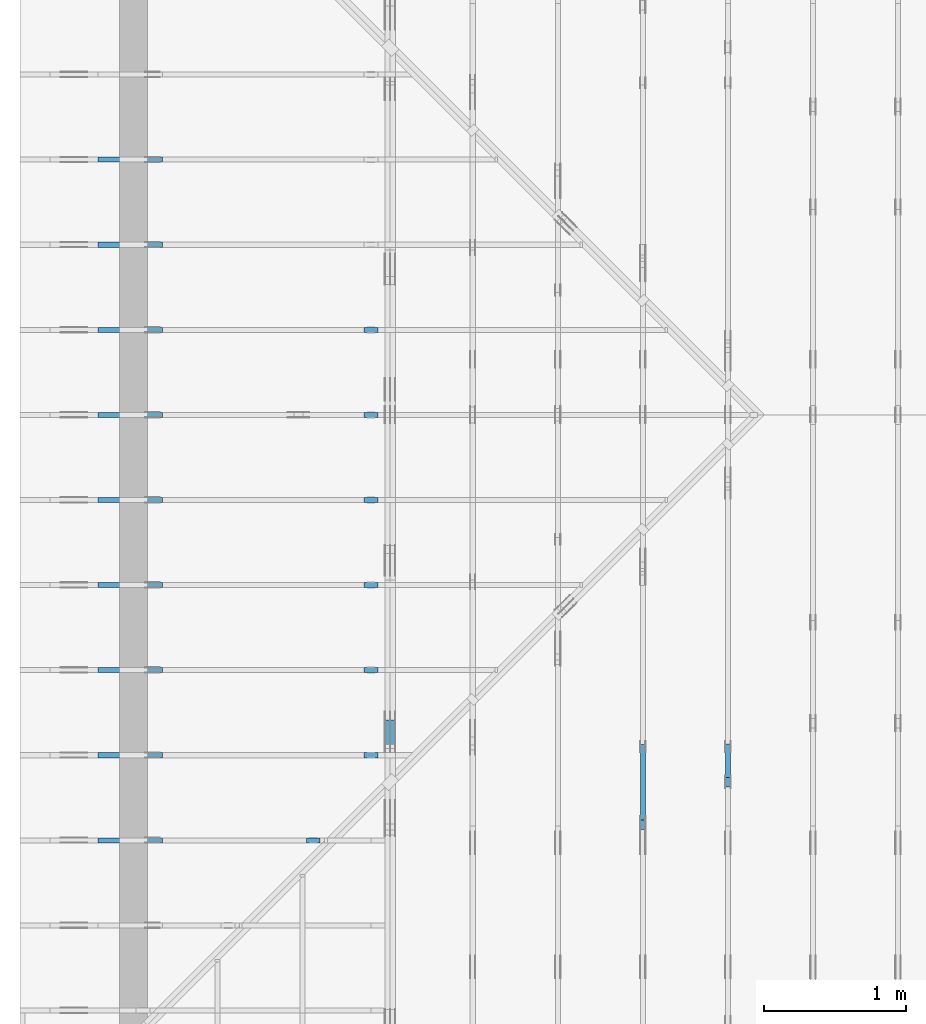
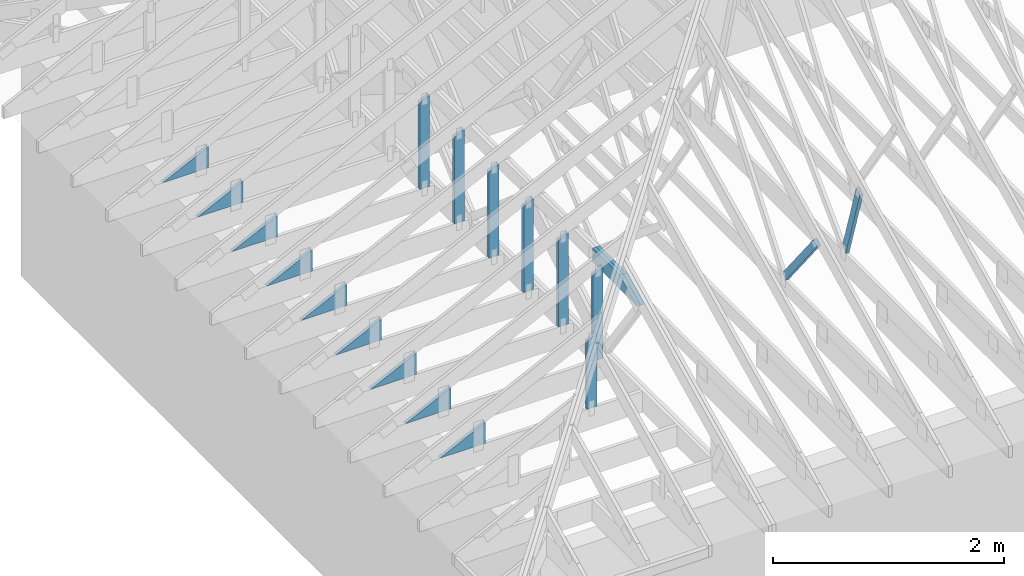
# One storey, part 42 of 159: 20 members, 12 elements without a shape of their own.
"""IFC2X3 building model written with IfcOpenShell, lengths in millimetres."""

from ifc_helpers import new_model, si_unit, frame, origin, origin_with_axes, origin_2d, place, context, project, spatial, faceted_brep, element, aggregate, save


model = new_model("IFC2X3")

# Units and contexts
model_context = context("Model", 3, precision=1e-05, world=origin())
plan_context = context("Plan", 2, precision=1e-05, world=origin_2d())
ifc_project = project(units=[si_unit("LENGTHUNIT", "METRE", prefix="MILLI"), si_unit("AREAUNIT", "SQUARE_METRE"), si_unit("VOLUMEUNIT", "CUBIC_METRE"), si_unit("SOLIDANGLEUNIT", "STERADIAN"), si_unit("PLANEANGLEUNIT", "RADIAN"), si_unit("MASSUNIT", "GRAM"), si_unit("TIMEUNIT", "SECOND"), si_unit("THERMODYNAMICTEMPERATUREUNIT", "DEGREE_CELSIUS"), si_unit("LUMINOUSINTENSITYUNIT", "LUMEN")], contexts=[model_context, plan_context])

# Site, building, storey
site_placement = place(None, origin_with_axes())
site = spatial("IfcSite", under=ifc_project, at=site_placement, CompositionType="ELEMENT")
building_placement = place(site_placement, origin_with_axes())
building = spatial("IfcBuilding", under=site, at=building_placement, Name="Plan 1", CompositionType="ELEMENT")
storey_placement = place(building_placement, origin_with_axes())
storey = spatial("IfcBuildingStorey", under=building, at=storey_placement, Name="Etasje 1", CompositionType="ELEMENT", Elevation=0.0)

# Assembly, members
assembly_1_placement = place(storey_placement, frame((-700.000000000007, 4482.000534935255, 1.1021457184401395e-15), z_axis=(0.0, -1.0, 6.123031769111886e-17), x_axis=(1.0, 0.0, 0.0)))
assembly_1 = element("IfcElementAssembly", 1, at=assembly_1_placement, inside=storey, Name="S1 (23)", AssemblyPlace="FACTORY", PredefinedType="TRUSS")
member_1_placement = place(assembly_1_placement, frame((2427.022216796875, 1186.87060546875, -36.0), z_axis=(0.0, 0.0, 1.0), x_axis=(-1.836909530733566e-16, -1.0, 0.0)))
member_1 = element("IfcMember", 2, at=member_1_placement, Name="S1-S10", context=model_context, shape_type="Brep", body=[
    faceted_brep([(963.87060546875, 98.0, 36.0), (0.0, 98.0, 36.0), (47.7978515625, 0.0, 36.0), (963.87060546875, 0.0, 36.0), (0.0, 98.0, 0.0), (963.87060546875, 98.0, 1.180362067719653e-13), (963.87060546875, 0.0, 1.180362067719653e-13), (47.7978515625, 0.0, 5.853355272249634e-15), (47.797842597319686, 4.460971103625866e-05, 3.2986355884658128e-31), (47.797842597319686, 4.460971103625866e-05, 36.0), (4.891787101968248e-05, 98.00004460971104, 36.0), (4.891787101968248e-05, 98.00004460971104, 6.658535629229929e-31), (963.87060546875, 4.4609710862757065e-05, 1.0841091630402093e-29), (963.87060546875, 4.4609710864961357e-05, 36.0), (47.797842597319686, 4.460971103323563e-05, 36.0), (47.797842597319686, 4.460971103103134e-05, 5.376041599078915e-31), (963.87060546875, 98.00004460971104, 0.0), (963.87060546875, 98.00004460971104, 36.0), (963.87060546875, 4.460971103981137e-05, 36.0), (963.87060546875, 4.460971103981137e-05, 0.0), (4.891787102678791e-05, 98.00004460971104, 0.0), (4.891787102678791e-05, 98.00004460971104, 36.0), (963.87060546875, 98.00004460971098, 36.0), (963.87060546875, 98.00004460971098, -3.944304526105059e-30)], [[[0, 1, 2, 3]], [[4, 5, 6, 7]], [[8, 9, 10, 11]], [[12, 13, 14, 15]], [[16, 17, 18, 19]], [[20, 21, 22, 23]]]),
])
member_2_placement = place(assembly_1_placement, frame((1006.0125131961246, 446.0, -36.0), z_axis=(0.0, 0.0, 1.0), x_axis=(-1.0, 3.940295897723878e-13, 0.0)))
member_2 = element("IfcMember", 3, at=member_2_placement, Name="S1-KI3", context=model_context, shape_type="Brep", body=[
    faceted_brep([(9.89005457086023e-07, 223.00000000000003, 36.0), (9.890933370115818e-07, 0.0, 36.0), (457.21777442650546, 223.0000000001802, 36.0), (9.89005457086023e-07, 223.00000000000003, 0.0), (457.21777442650546, 223.0000000001802, 0.0), (9.890933370115818e-07, 0.0, 0.0), (8.787992555880918e-11, -5.877471754111438e-39, 7.174648137343064e-43), (8.788212985024606e-11, 8.680161727469901e-28, 36.0), (6.814877438404889e-14, 223.00000000000003, 36.0), (6.594448294716861e-14, 223.00000000000003, -4.037801640831852e-30), (457.21775667363465, 223.00000000018002, 1.2755715925633707e-29), (457.21775667363465, 223.00000000018002, 36.0), (8.787895926104418e-11, 1.9812040197486523e-15, 36.0), (8.787992555880922e-11, -2.5849394142282115e-26, 1.6783238894948193e-42), (0.0, 223.00000000000003, 0.0), (0.0, 223.00000000000003, 36.0), (457.21775667363454, 223.0000000001802, 36.0), (457.21775667363454, 223.0000000001802, 0.0)], [[[0, 1, 2]], [[3, 4, 5]], [[6, 7, 8, 9]], [[10, 11, 12, 13]], [[14, 15, 16, 17]]]),
])
aggregate(assembly_1, [member_1, member_2])

assembly_2_placement = place(storey_placement, frame((-700.000000000007, 3882.0074014212605, 1.1021457184401395e-15), z_axis=(0.0, -1.0, 6.123031769111886e-17), x_axis=(1.0, 0.0, 0.0)))
assembly_2 = element("IfcElementAssembly", 4, at=assembly_2_placement, inside=storey, Name="S2 (21)", AssemblyPlace="FACTORY", PredefinedType="TRUSS")
member_3_placement = place(assembly_2_placement, frame((2427.022216796875, 1186.87060546875, -36.0), z_axis=(0.0, 0.0, 1.0), x_axis=(-1.836909530733566e-16, -1.0, 0.0)))
member_3 = element("IfcMember", 5, at=member_3_placement, Name="S2-S10", context=model_context, shape_type="Brep", body=[
    faceted_brep([(963.87060546875, 98.0, 36.0), (0.0, 98.0, 36.0), (47.7978515625, 0.0, 36.0), (963.87060546875, 0.0, 36.0), (0.0, 98.0, 0.0), (963.87060546875, 98.0, 1.180362067719653e-13), (963.87060546875, 0.0, 1.180362067719653e-13), (47.7978515625, 0.0, 5.853355272249634e-15), (47.797842596999544, 4.460974014364183e-05, 0.0), (47.79784259699955, 4.460974014364183e-05, 36.0), (4.891752906388547e-05, 98.00004460974016, 36.0), (4.891752906388547e-05, 98.00004460974016, -7.888609052210118e-31), (963.87060546875, 4.460972531625816e-05, 1.6867020609779444e-29), (963.87060546875, 4.460972531846245e-05, 36.0), (47.797842596999544, 4.4609740132185783e-05, 36.0), (47.797842596999544, 4.460974012998149e-05, 8.364268609490694e-31), (963.87060546875, 98.00004460972559, 0.0), (963.87060546875, 98.00004460972559, 36.0), (963.87060546875, 4.46097255917266e-05, 36.0), (963.87060546875, 4.46097255917266e-05, 0.0), (4.891752905678004e-05, 98.00004460974014, 0.0), (4.891752905678004e-05, 98.00004460974014, 36.0), (963.87060546875, 98.00004460972553, 36.0), (963.87060546875, 98.00004460972553, -3.944304526105059e-30)], [[[0, 1, 2, 3]], [[4, 5, 6, 7]], [[8, 9, 10, 11]], [[12, 13, 14, 15]], [[16, 17, 18, 19]], [[20, 21, 22, 23]]]),
])
member_4_placement = place(assembly_2_placement, frame((1006.0125131960257, 446.0, -36.0), z_axis=(0.0, 0.0, 1.0), x_axis=(-1.0, 3.940295897723878e-13, 0.0)))
member_4 = element("IfcMember", 6, at=member_4_placement, Name="S2-KI3", context=model_context, shape_type="Brep", body=[
    faceted_brep([(9.889065495372051e-07, 223.00000000000003, 36.0), (9.88994429462764e-07, 0.0, 36.0), (457.21777442640655, 223.0000000001802, 36.0), (9.889065495372051e-07, 223.00000000000003, 0.0), (457.21777442640655, 223.0000000001802, 0.0), (9.88994429462764e-07, 0.0, 0.0), (8.787992555880918e-11, -5.877471754111438e-39, 7.174648137343064e-43), (8.788212985024606e-11, 8.680161727469901e-28, 36.0), (6.814877438404889e-14, 223.00000000000003, 36.0), (6.594448294716861e-14, 223.00000000000003, -4.037801640831852e-30), (457.21775667353575, 223.00000000018005, 1.2765880635177245e-29), (457.21775667353575, 223.00000000018005, 36.0), (8.787895926104418e-11, 1.9812040197486523e-15, 36.0), (8.787992555880922e-11, -2.5849394142282115e-26, 2.152394441202919e-42), (0.0, 223.00000000000003, 0.0), (0.0, 223.00000000000003, 36.0), (457.21775667353563, 223.0000000001802, 36.0), (457.21775667353563, 223.0000000001802, 0.0)], [[[0, 1, 2]], [[3, 4, 5]], [[6, 7, 8, 9]], [[10, 11, 12, 13]], [[14, 15, 16, 17]]]),
])
aggregate(assembly_2, [member_3, member_4])

assembly_3_placement = place(storey_placement, frame((-700.000000000007, 3282.0074014212605, 1.1021457184401395e-15), z_axis=(0.0, -1.0, 6.123031769111886e-17), x_axis=(1.0, 0.0, 0.0)))
assembly_3 = element("IfcElementAssembly", 7, at=assembly_3_placement, inside=storey, Name="S3 (19)", AssemblyPlace="FACTORY", PredefinedType="TRUSS")
member_5_placement = place(assembly_3_placement, frame((2427.022216796875, 1186.87060546875, -36.0), z_axis=(0.0, 0.0, 1.0), x_axis=(-1.836909530733566e-16, -1.0, 0.0)))
member_5 = element("IfcMember", 8, at=member_5_placement, Name="S3-S10", context=model_context, shape_type="Brep", body=[
    faceted_brep([(963.87060546875, 98.0, 36.0), (0.0, 98.0, 36.0), (47.7978515625, 0.0, 36.0), (963.87060546875, 0.0, 36.0), (0.0, 98.0, 0.0), (963.87060546875, 98.0, 1.180362067719653e-13), (963.87060546875, 0.0, 1.180362067719653e-13), (47.7978515625, 0.0, 5.853355272249634e-15), (47.79784259663575, 4.46097255917266e-05, -3.944304526105059e-31), (47.79784259663575, 4.46097255917266e-05, 36.0), (4.891715071408953e-05, 98.00004460972562, 36.0), (4.891715071408953e-05, 98.00004460972562, -7.888609052210118e-31), (963.87060546875, 4.4609725414672293e-05, 1.0841091630402093e-29), (963.87060546875, 4.4609725416876585e-05, 36.0), (47.797842596635746, 4.460972558515086e-05, 36.0), (47.797842596635746, 4.460972558294657e-05, 5.376041599078915e-31), (963.87060546875, 98.00004460972559, 0.0), (963.87060546875, 98.00004460972559, 36.0), (963.87060546875, 4.46097255917266e-05, 36.0), (963.87060546875, 4.46097255917266e-05, 0.0), (4.89171507069841e-05, 98.00004460972559, 0.0), (4.89171507069841e-05, 98.00004460972559, 36.0), (963.87060546875, 98.00004460972553, 36.0), (963.87060546875, 98.00004460972553, -3.944304526105059e-30)], [[[0, 1, 2, 3]], [[4, 5, 6, 7]], [[8, 9, 10, 11]], [[12, 13, 14, 15]], [[16, 17, 18, 19]], [[20, 21, 22, 23]]]),
])
member_6_placement = place(assembly_3_placement, frame((1006.0125131975241, 446.0, -36.0), z_axis=(0.0, 0.0, 1.0), x_axis=(-1.0, 3.940295897723878e-13, 0.0)))
member_6 = element("IfcMember", 9, at=member_6_placement, Name="S3-KI3", context=model_context, shape_type="Brep", body=[
    faceted_brep([(9.90404942058376e-07, 223.00000000000003, 36.0), (9.904928219839348e-07, 0.0, 36.0), (457.21777442790494, 223.0000000001802, 36.0), (9.90404942058376e-07, 223.00000000000003, 0.0), (457.21777442790494, 223.0000000001802, 0.0), (9.904928219839348e-07, 0.0, 0.0), (8.787992555880918e-11, -5.877471754111438e-39, 7.174648137343064e-43), (8.788212985024606e-11, 8.680161727469901e-28, 36.0), (6.814877438404889e-14, 223.00000000000003, 36.0), (6.594448294716861e-14, 223.00000000000003, -4.037801640831852e-30), (457.2177566731714, 223.00000000018028, -6.1566163794773226e-30), (457.2177566731714, 223.00000000018028, 36.0), (8.787895926104415e-11, 1.9812040197874264e-15, 36.0), (8.787992555880919e-11, 1.2924697071141057e-26, -6.021266688933124e-43), (0.0, 223.00000000000003, 0.0), (0.0, 223.00000000000003, 36.0), (457.2177566731714, 223.0000000001802, 36.0), (457.2177566731714, 223.0000000001802, 0.0)], [[[0, 1, 2]], [[3, 4, 5]], [[6, 7, 8, 9]], [[10, 11, 12, 13]], [[14, 15, 16, 17]]]),
])
aggregate(assembly_3, [member_5, member_6])

assembly_4_placement = place(storey_placement, frame((-700.000000000007, 1482.0074014212605, 1.1021457184401395e-15), z_axis=(0.0, -1.0, 6.123031769111886e-17), x_axis=(1.0, 0.0, 0.0)))
assembly_4 = element("IfcElementAssembly", 10, at=assembly_4_placement, inside=storey, Name="S6 (18)", AssemblyPlace="FACTORY", PredefinedType="TRUSS")
member_7_placement = place(assembly_4_placement, frame((2019.0946044921875, 987.9109634285778, -36.0), z_axis=(0.0, 0.0, 1.0), x_axis=(-1.836909530733566e-16, -1.0, 0.0)))
member_7 = element("IfcMember", 11, at=member_7_placement, Name="S6-S11", context=model_context, shape_type="Brep", body=[
    faceted_brep([(764.9109634285778, 98.00012207031273, 36.0), (1.3721546565648168e-05, 98.00012207031273, 36.0), (47.797804248890316, 0.0, 36.0), (764.9109634285778, 0.0, 36.0), (1.3721546565648168e-05, 98.00012207031273, 1.6803493108562366e-21), (764.9109634285778, 98.00012207031273, 9.367148259230324e-14), (764.9109634285778, 0.0, 9.367148259230324e-14), (47.797804248890316, 0.0, 5.85334947819493e-15), (47.797793679492315, 3.881497832480818e-05, 4.5899729634377065e-31), (47.797793679492315, 3.881497832480818e-05, 36.0), (0.0, 98.00003881497855, 36.0), (0.0, 98.00003881497855, -2.714231603432065e-31), (764.9109634285778, 3.881496419277258e-05, -1.1787200201684015e-29), (764.9109634285778, 3.881496419497687e-05, 36.0), (47.797793679492315, 3.881497833904179e-05, 36.0), (47.797793679492315, 3.88149783368375e-05, -7.365591178523614e-31), (764.9109634285778, 98.000038814964, 0.0), (764.9109634285778, 98.000038814964, 36.0), (764.9109634285778, 3.881496400026663e-05, 36.0), (764.9109634285778, 3.881496400026663e-05, 0.0), (0.0, 98.00003881497855, 0.0), (0.0, 98.00003881497855, 36.0), (764.9109634285778, 98.00003881496407, 36.0), (764.9109634285778, 98.00003881496407, 3.944304526105059e-30)], [[[0, 1, 2, 3]], [[4, 5, 6, 7]], [[8, 9, 10, 11]], [[12, 13, 14, 15]], [[16, 17, 18, 19]], [[20, 21, 22, 23]]]),
])
member_8_placement = place(assembly_4_placement, frame((1006.0125131974663, 446.0, -36.0), z_axis=(0.0, 0.0, 1.0), x_axis=(-1.0, 3.940295897723878e-13, 0.0)))
member_8 = element("IfcMember", 12, at=member_8_placement, Name="S6-KI3", context=model_context, shape_type="Brep", body=[
    faceted_brep([(9.903471891448135e-07, 223.00000000000003, 36.0), (9.904350690703723e-07, 0.0, 36.0), (457.2177744278472, 223.0000000001802, 36.0), (9.903471891448135e-07, 223.00000000000003, 0.0), (457.2177744278472, 223.0000000001802, 0.0), (9.904350690703723e-07, 0.0, 0.0), (8.787992555880918e-11, -5.877471754111438e-39, 7.174648137343064e-43), (8.788212985024606e-11, 8.680161727469901e-28, 36.0), (6.814877438404889e-14, 223.00000000000003, 36.0), (6.594448294716861e-14, 223.00000000000003, -4.037801640831852e-30), (457.2177566731137, 223.0000000001803, -4.57889456879443e-30), (457.2177566731137, 223.0000000001803, 36.0), (8.787895926104415e-11, 1.981204019780964e-15, 36.0), (8.787992555880919e-11, 6.462348535570529e-27, -6.021266688933065e-43), (0.0, 223.00000000000003, 0.0), (0.0, 223.00000000000003, 36.0), (457.2177566731136, 223.0000000001802, 36.0), (457.2177566731136, 223.0000000001802, 0.0)], [[[0, 1, 2]], [[3, 4, 5]], [[6, 7, 8, 9]], [[10, 11, 12, 13]], [[14, 15, 16, 17]]]),
])
aggregate(assembly_4, [member_7, member_8])

assembly_5_placement = place(storey_placement, frame((-700.000000000007, 2682.0074014212605, 1.1021457184401395e-15), z_axis=(0.0, -1.0, 6.123031769111886e-17), x_axis=(1.0, 0.0, 0.0)))
assembly_5 = element("IfcElementAssembly", 13, at=assembly_5_placement, inside=storey, Name="S4 (17)", AssemblyPlace="FACTORY", PredefinedType="TRUSS")
member_9_placement = place(assembly_5_placement, frame((2427.022216796875, 1186.87060546875, -36.0), z_axis=(0.0, 0.0, 1.0), x_axis=(-1.836909530733566e-16, -1.0, 0.0)))
member_9 = element("IfcMember", 14, at=member_9_placement, Name="S4-S10", context=model_context, shape_type="Brep", body=[
    faceted_brep([(963.87060546875, 98.0, 36.0), (0.0, 98.0, 36.0), (47.7978515625, 0.0, 36.0), (963.87060546875, 0.0, 36.0), (0.0, 98.0, 0.0), (963.87060546875, 98.0, 1.180362067719653e-13), (963.87060546875, 0.0, 1.180362067719653e-13), (47.7978515625, 0.0, 5.853355272249634e-15), (47.7978425961337, 4.460971103981137e-05, 3.944304526105059e-31), (47.7978425961337, 4.460971103981137e-05, 36.0), (4.8916626859352164e-05, 98.00004460972562, 36.0), (4.8916626859352164e-05, 98.00004460972562, -1.5777218104420236e-30), (963.87060546875, 4.460972551308643e-05, 4.815162651024742e-30), (963.87060546875, 4.460972551529072e-05, 36.0), (47.797842596133705, 4.460971103811594e-05, 36.0), (47.797842596133705, 4.460971103591165e-05, 2.3878145886671356e-31), (963.87060546875, 98.00004460972559, 0.0), (963.87060546875, 98.00004460972559, 36.0), (963.87060546875, 4.46097255917266e-05, 36.0), (963.87060546875, 4.46097255917266e-05, 0.0), (4.891662683803588e-05, 98.00004460972559, 0.0), (4.891662683803588e-05, 98.00004460972559, 36.0), (963.87060546875, 98.00004460972553, 36.0), (963.87060546875, 98.00004460972553, -3.944304526105059e-30)], [[[0, 1, 2, 3]], [[4, 5, 6, 7]], [[8, 9, 10, 11]], [[12, 13, 14, 15]], [[16, 17, 18, 19]], [[20, 21, 22, 23]]]),
])
member_10_placement = place(assembly_5_placement, frame((1006.0125131973072, 446.0, -36.0), z_axis=(0.0, 0.0, 1.0), x_axis=(-1.0, 3.940295897723878e-13, 0.0)))
member_10 = element("IfcMember", 15, at=member_10_placement, Name="S4-KI3", context=model_context, shape_type="Brep", body=[
    faceted_brep([(9.901880275720032e-07, 223.00000000000003, 36.0), (9.90275907497562e-07, 0.0, 36.0), (457.217774427688, 223.0000000001802, 36.0), (9.901880275720032e-07, 223.00000000000003, 0.0), (457.217774427688, 223.0000000001802, 0.0), (9.90275907497562e-07, 0.0, 0.0), (8.787992555880918e-11, -5.877471754111438e-39, 7.174648137343064e-43), (8.788212985024606e-11, 8.680161727469901e-28, 36.0), (6.814877438404889e-14, 223.00000000000003, 36.0), (6.594448294716861e-14, 223.00000000000003, -4.037801640831852e-30), (457.2177566729545, 223.0000000001801, 6.454993395830235e-30), (457.2177566729545, 223.0000000001801, 36.0), (8.787895926104415e-11, 1.981204019761577e-15, 36.0), (8.787992555880919e-11, -1.2924697071141057e-26, 3.587324068671532e-43), (0.0, 223.00000000000003, 0.0), (0.0, 223.00000000000003, 36.0), (457.21775667295447, 223.0000000001802, 36.0), (457.21775667295447, 223.0000000001802, 0.0)], [[[0, 1, 2]], [[3, 4, 5]], [[6, 7, 8, 9]], [[10, 11, 12, 13]], [[14, 15, 16, 17]]]),
])
aggregate(assembly_5, [member_9, member_10])

assembly_6_placement = place(storey_placement, frame((-700.000000000007, 5081.993668449246, 1.1021457184401395e-15), z_axis=(0.0, -1.0, 6.123031769111886e-17), x_axis=(1.0, 0.0, 0.0)))
assembly_6 = element("IfcElementAssembly", 16, at=assembly_6_placement, inside=storey, Name="S2 (15)", AssemblyPlace="FACTORY", PredefinedType="TRUSS")
member_11_placement = place(assembly_6_placement, frame((2427.022216796875, 1186.87060546875, -36.0), z_axis=(0.0, 0.0, 1.0), x_axis=(-1.836909530733566e-16, -1.0, 0.0)))
member_11 = element("IfcMember", 17, at=member_11_placement, Name="S2-S10", context=model_context, shape_type="Brep", body=[
    faceted_brep([(963.87060546875, 98.0, 36.0), (0.0, 98.0, 36.0), (47.7978515625, 0.0, 36.0), (963.87060546875, 0.0, 36.0), (0.0, 98.0, 0.0), (963.87060546875, 98.0, 1.180362067719653e-13), (963.87060546875, 0.0, 1.180362067719653e-13), (47.7978515625, 0.0, 5.853355272249634e-15), (47.797842596999544, 4.460974014364183e-05, 0.0), (47.79784259699955, 4.460974014364183e-05, 36.0), (4.891752906388547e-05, 98.00004460974016, 36.0), (4.891752906388547e-05, 98.00004460974016, -7.888609052210118e-31), (963.87060546875, 4.460972531625816e-05, 1.6867020609779444e-29), (963.87060546875, 4.460972531846245e-05, 36.0), (47.797842596999544, 4.4609740132185783e-05, 36.0), (47.797842596999544, 4.460974012998149e-05, 8.364268609490694e-31), (963.87060546875, 98.00004460972559, 0.0), (963.87060546875, 98.00004460972559, 36.0), (963.87060546875, 4.46097255917266e-05, 36.0), (963.87060546875, 4.46097255917266e-05, 0.0), (4.891752905678004e-05, 98.00004460974014, 0.0), (4.891752905678004e-05, 98.00004460974014, 36.0), (963.87060546875, 98.00004460972553, 36.0), (963.87060546875, 98.00004460972553, -3.944304526105059e-30)], [[[0, 1, 2, 3]], [[4, 5, 6, 7]], [[8, 9, 10, 11]], [[12, 13, 14, 15]], [[16, 17, 18, 19]], [[20, 21, 22, 23]]]),
])
member_12_placement = place(assembly_6_placement, frame((1006.0125131960257, 446.0, -36.0), z_axis=(0.0, 0.0, 1.0), x_axis=(-1.0, 3.940295897723878e-13, 0.0)))
member_12 = element("IfcMember", 18, at=member_12_placement, Name="S2-KI3", context=model_context, shape_type="Brep", body=[
    faceted_brep([(9.889065495372051e-07, 223.00000000000003, 36.0), (9.88994429462764e-07, 0.0, 36.0), (457.21777442640655, 223.0000000001802, 36.0), (9.889065495372051e-07, 223.00000000000003, 0.0), (457.21777442640655, 223.0000000001802, 0.0), (9.88994429462764e-07, 0.0, 0.0), (8.787992555880918e-11, -5.877471754111438e-39, 7.174648137343064e-43), (8.788212985024606e-11, 8.680161727469901e-28, 36.0), (6.814877438404889e-14, 223.00000000000003, 36.0), (6.594448294716861e-14, 223.00000000000003, -4.037801640831852e-30), (457.21775667353575, 223.00000000018005, 1.2765880635177245e-29), (457.21775667353575, 223.00000000018005, 36.0), (8.787895926104418e-11, 1.9812040197486523e-15, 36.0), (8.787992555880922e-11, -2.5849394142282115e-26, 2.152394441202919e-42), (0.0, 223.00000000000003, 0.0), (0.0, 223.00000000000003, 36.0), (457.21775667353563, 223.0000000001802, 36.0), (457.21775667353563, 223.0000000001802, 0.0)], [[[0, 1, 2]], [[3, 4, 5]], [[6, 7, 8, 9]], [[10, 11, 12, 13]], [[14, 15, 16, 17]]]),
])
aggregate(assembly_6, [member_11, member_12])

# Assembly, member
assembly_7_placement = place(storey_placement, frame((-700.000000000007, 5681.993668449246, 1.1021457184401395e-15), z_axis=(0.0, -1.0, 6.123031769111886e-17), x_axis=(1.0, 0.0, 0.0)))
assembly_7 = element("IfcElementAssembly", 19, at=assembly_7_placement, inside=storey, Name="S3 (13)", AssemblyPlace="FACTORY", PredefinedType="TRUSS")
member_13_placement = place(assembly_7_placement, frame((1006.0125131975241, 446.0, -36.0), z_axis=(0.0, 0.0, 1.0), x_axis=(-1.0, 3.940295897723878e-13, 0.0)))
member_13 = element("IfcMember", 20, at=member_13_placement, Name="S3-KI3", context=model_context, shape_type="Brep", body=[
    faceted_brep([(9.90404942058376e-07, 223.00000000000003, 36.0), (9.904928219839348e-07, 0.0, 36.0), (457.21777442790494, 223.0000000001802, 36.0), (9.90404942058376e-07, 223.00000000000003, 0.0), (457.21777442790494, 223.0000000001802, 0.0), (9.904928219839348e-07, 0.0, 0.0), (8.787992555880918e-11, -5.877471754111438e-39, 7.174648137343064e-43), (8.788212985024606e-11, 8.680161727469901e-28, 36.0), (6.814877438404889e-14, 223.00000000000003, 36.0), (6.594448294716861e-14, 223.00000000000003, -4.037801640831852e-30), (457.2177566731714, 223.00000000018028, -6.1566163794773226e-30), (457.2177566731714, 223.00000000018028, 36.0), (8.787895926104415e-11, 1.9812040197874264e-15, 36.0), (8.787992555880919e-11, 1.2924697071141057e-26, -6.021266688933124e-43), (0.0, 223.00000000000003, 0.0), (0.0, 223.00000000000003, 36.0), (457.2177566731714, 223.0000000001802, 36.0), (457.2177566731714, 223.0000000001802, 0.0)], [[[0, 1, 2]], [[3, 4, 5]], [[6, 7, 8, 9]], [[10, 11, 12, 13]], [[14, 15, 16, 17]]]),
])
aggregate(assembly_7, [member_13])

assembly_8_placement = place(storey_placement, frame((-700.000000000007, 6281.993668449246, 1.1021457184401395e-15), z_axis=(0.0, -1.0, 6.123031769111886e-17), x_axis=(1.0, 0.0, 0.0)))
assembly_8 = element("IfcElementAssembly", 21, at=assembly_8_placement, inside=storey, Name="S4 (11)", AssemblyPlace="FACTORY", PredefinedType="TRUSS")
member_14_placement = place(assembly_8_placement, frame((1006.0125131973072, 446.0, -36.0), z_axis=(0.0, 0.0, 1.0), x_axis=(-1.0, 3.940295897723878e-13, 0.0)))
member_14 = element("IfcMember", 22, at=member_14_placement, Name="S4-KI3", context=model_context, shape_type="Brep", body=[
    faceted_brep([(9.901880275720032e-07, 223.00000000000003, 36.0), (9.90275907497562e-07, 0.0, 36.0), (457.217774427688, 223.0000000001802, 36.0), (9.901880275720032e-07, 223.00000000000003, 0.0), (457.217774427688, 223.0000000001802, 0.0), (9.90275907497562e-07, 0.0, 0.0), (8.787992555880918e-11, -5.877471754111438e-39, 7.174648137343064e-43), (8.788212985024606e-11, 8.680161727469901e-28, 36.0), (6.814877438404889e-14, 223.00000000000003, 36.0), (6.594448294716861e-14, 223.00000000000003, -4.037801640831852e-30), (457.2177566729545, 223.0000000001801, 6.454993395830235e-30), (457.2177566729545, 223.0000000001801, 36.0), (8.787895926104415e-11, 1.981204019761577e-15, 36.0), (8.787992555880919e-11, -1.2924697071141057e-26, 3.587324068671532e-43), (0.0, 223.00000000000003, 0.0), (0.0, 223.00000000000003, 36.0), (457.21775667295447, 223.0000000001802, 36.0), (457.21775667295447, 223.0000000001802, 0.0)], [[[0, 1, 2]], [[3, 4, 5]], [[6, 7, 8, 9]], [[10, 11, 12, 13]], [[14, 15, 16, 17]]]),
])
aggregate(assembly_8, [member_14])

# Assembly, members
assembly_9_placement = place(storey_placement, frame((-700.000000000007, 2082.0074014212605, 1.1021457184401395e-15), z_axis=(0.0, -1.0, 6.123031769111886e-17), x_axis=(1.0, 0.0, 0.0)))
assembly_9 = element("IfcElementAssembly", 23, at=assembly_9_placement, inside=storey, Name="S5 (10)", AssemblyPlace="FACTORY", PredefinedType="TRUSS")
member_15_placement = place(assembly_9_placement, frame((2427.022216796875, 1186.87060546875, -36.0), z_axis=(0.0, 0.0, 1.0), x_axis=(-1.836909530733566e-16, -1.0, 0.0)))
member_15 = element("IfcMember", 24, at=member_15_placement, Name="S5-S10", context=model_context, shape_type="Brep", body=[
    faceted_brep([(963.87060546875, 98.0, 36.0), (0.0, 98.0, 36.0), (47.7978515625, 0.0, 36.0), (963.87060546875, 0.0, 36.0), (0.0, 98.0, 0.0), (963.87060546875, 98.0, 1.180362067719653e-13), (963.87060546875, 0.0, 1.180362067719653e-13), (47.7978515625, 0.0, 5.853355272249634e-15), (47.797842597035924, 4.46097255917266e-05, -3.944304526105059e-31), (47.797842597035924, 4.46097255917266e-05, 36.0), (4.89175727054203e-05, 98.00004460971103, 36.0), (4.89175727054203e-05, 98.00004460971103, 3.944304526105059e-31), (963.87060546875, 4.460971076434293e-05, 1.6867020609779444e-29), (963.87060546875, 4.460971076654722e-05, 36.0), (47.797842597035924, 4.4609725580270555e-05, 36.0), (47.797842597035924, 4.4609725578066264e-05, 8.364268609490694e-31), (963.87060546875, 98.00004460971104, 0.0), (963.87060546875, 98.00004460971104, 36.0), (963.87060546875, 4.460971103981137e-05, 36.0), (963.87060546875, 4.460971103981137e-05, 0.0), (4.8917572712525725e-05, 98.00004460971104, 0.0), (4.8917572712525725e-05, 98.00004460971104, 36.0), (963.87060546875, 98.00004460971098, 36.0), (963.87060546875, 98.00004460971098, -3.944304526105059e-30)], [[[0, 1, 2, 3]], [[4, 5, 6, 7]], [[8, 9, 10, 11]], [[12, 13, 14, 15]], [[16, 17, 18, 19]], [[20, 21, 22, 23]]]),
])
member_16_placement = place(assembly_9_placement, frame((1006.0125131977583, 446.0, -36.0), z_axis=(0.0, 0.0, 1.0), x_axis=(-1.0, 3.940295897723878e-13, 0.0)))
member_16 = element("IfcMember", 25, at=member_16_placement, Name="S5-KI3", context=model_context, shape_type="Brep", body=[
    faceted_brep([(9.906391369440826e-07, 223.00000000000003, 36.0), (9.907270168696414e-07, 0.0, 36.0), (457.21777442813914, 223.0000000001802, 36.0), (9.906391369440826e-07, 223.00000000000003, 0.0), (457.21777442813914, 223.0000000001802, 0.0), (9.907270168696414e-07, 0.0, 0.0), (8.787992555880918e-11, -5.877471754111438e-39, 7.174648137343064e-43), (8.788212985024606e-11, 8.680161727469901e-28, 36.0), (6.814877438404889e-14, 223.00000000000003, 36.0), (6.594448294716861e-14, 223.00000000000003, -4.037801640831852e-30), (457.21775667340563, 223.00000000017994, 1.7488881357913373e-29), (457.21775667340563, 223.00000000017994, 36.0), (8.787895926104418e-11, 1.98120401974219e-15, 36.0), (8.787992555880922e-11, -3.2311742677852644e-26, 2.3957887032291024e-42), (0.0, 223.00000000000003, 0.0), (0.0, 223.00000000000003, 36.0), (457.2177566734056, 223.0000000001802, 36.0), (457.2177566734056, 223.0000000001802, 0.0)], [[[0, 1, 2]], [[3, 4, 5]], [[6, 7, 8, 9]], [[10, 11, 12, 13]], [[14, 15, 16, 17]]]),
])
aggregate(assembly_9, [member_15, member_16])

# Assembly, member
assembly_10_placement = place(storey_placement, frame((3675.02226140475, 9699.999999999993, 1.1021457184401395e-15), z_axis=(-1.0, 1.836909530733566e-16, 6.123031769111886e-17), x_axis=(-1.836909530733566e-16, -1.0, 0.0)))
assembly_10 = element("IfcElementAssembly", 26, at=assembly_10_placement, inside=storey, Name="V4 (5)", AssemblyPlace="FACTORY", PredefinedType="TRUSS")
member_17_placement = place(assembly_10_placement, frame((8066.253357387588, 1111.1104367698422, -36.0), z_axis=(0.0, 0.0, 1.0), x_axis=(-0.6220450126160857, -0.7829814827181124, 0.0)))
member_17 = element("IfcMember", 27, at=member_17_placement, Name="V4-D57", context=model_context, shape_type="Brep", body=[
    faceted_brep([(887.251018129381, 73.00005326104929, 36.0), (0.0, 73.00005326104929, 36.0), (16.137930632528878, 7.185764843598008e-06, 36.0), (868.7646255067611, 7.185764843598008e-06, 36.0), (0.0, 73.00005326104929, 0.0), (887.251018129381, 73.00005326104929, 1.0865332342366132e-13), (868.7646255067611, 7.185764843598008e-06, 1.0638946803716978e-13), (16.137930632528878, 7.185764843598008e-06, 1.976261239013964e-15), (16.13787620565563, 4.440892098500626e-16, 0.0), (16.137876205655633, 8.881784197001252e-16, 36.0), (0.00010725910760633894, 72.9999999999991, 36.0), (0.00010725910760456259, 72.9999999999991, 1.9721522630525295e-31), (868.7647499471996, 2.1036274009308134e-12, 3.8260174521101025e-29), (868.7647499471996, 2.1058316923676936e-12, 36.0), (16.13787620565563, -9.402832519633726e-15, 36.0), (16.13787620565563, -1.1607123956514006e-14, 7.107078873375486e-31), (887.2510604429846, 73.00000000000279, 8.892423616001774e-31), (887.2510604429846, 73.00000000000279, 36.0), (868.7647499471997, 2.7569058147491887e-12, 36.0), (868.7647499471997, 2.7569058147491887e-12, -5.653694294607796e-30), (0.0001072591076081153, 72.99999999999909, 0.0), (0.0001072591076081153, 72.99999999999909, 36.0), (887.2510604429845, 73.00000000000277, 36.0), (887.2510604429845, 73.00000000000279, 2.3665827156630354e-30)], [[[0, 1, 2, 3]], [[4, 5, 6, 7]], [[8, 9, 10, 11]], [[12, 13, 14, 15]], [[16, 17, 18, 19]], [[20, 21, 22, 23]]]),
])
aggregate(assembly_10, [member_17])

# Assembly, members
assembly_11_placement = place(storey_placement, frame((1875.0222614047502, 9699.999999999993, 0.0), z_axis=(-1.0, 1.836909530733566e-16, 6.123031769111886e-17), x_axis=(-1.836909530733566e-16, -1.0, 0.0)))
assembly_11 = element("IfcElementAssembly", 28, at=assembly_11_placement, inside=storey, Name="V1 (2)", AssemblyPlace="FACTORY", PredefinedType="TRUSS")
member_18_placement = place(assembly_11_placement, frame((7351.5771484375, 1063.2571859793243, -36.0), z_axis=(0.0, 0.0, 1.0), x_axis=(1.0, 0.0, 0.0)))
member_18 = element("IfcMember", 29, at=member_18_placement, Name="V1-O73", context=model_context, shape_type="Brep", body=[
    faceted_brep([(473.3994140625, 148.00001616911322, 36.0), (0.0, 148.00001616911322, 36.0), (0.0, 1.6169113223440945e-05, 36.0), (776.8447265625, 1.6169113223440945e-05, 36.0), (0.0, 148.00001616911322, 0.0), (473.3994140625, 148.00001616911322, 5.79727930356728e-14), (776.8447265625, 1.6169113223440945e-05, 9.513289880818448e-14), (0.0, 1.6169113223440945e-05, 0.0), (0.00014441402254306013, 8.412825991399586e-12, 0.0), (0.00014441402254526442, 8.412825991399586e-12, 36.0), (0.0001444140225633886, 148.0000000000084, 36.0), (0.0001444140225611843, 148.0000000000084, -1.1097494219785373e-30), (776.8444888441009, -9.589874667803065e-15, 5.871910725276035e-31), (776.8444888441009, -7.385583230922786e-15, 36.0), (0.00014441402254306013, 8.415030281053726e-12, 36.0), (0.00014441402254306013, 8.412825989616846e-12, 1.0915778725458887e-37), (473.3995202907681, 148.00000000000006, 3.1554436208840472e-30), (473.3995202907681, 148.00000000000006, 36.0), (776.844488844101, 5.684341886080802e-14, 36.0), (776.844488844101, 5.684341886080802e-14, 3.1554436208840472e-30), (0.00014441402254306013, 148.0000000000084, 0.0), (0.00014441402254306013, 148.0000000000084, 36.0), (473.3995202907681, 147.99999999999997, 36.0), (473.3995202907681, 147.99999999999997, -1.5777218104420236e-30)], [[[0, 1, 2, 3]], [[4, 5, 6, 7]], [[8, 9, 10, 11]], [[12, 13, 14, 15]], [[16, 17, 18, 19]], [[20, 21, 22, 23]]]),
])
member_19_placement = place(assembly_11_placement, frame((7351.5771484375, 1063.2571859793243, -72.0), z_axis=(0.0, 0.0, 1.0), x_axis=(1.0, 0.0, 0.0)))
member_19 = element("IfcMember", 30, at=member_19_placement, Name="V1-O73", context=model_context, shape_type="Brep", body=[
    faceted_brep([(473.3994140625, 148.00001616911322, 36.0), (0.0, 148.00001616911322, 36.0), (0.0, 1.6169113223440945e-05, 36.0), (776.8447265625, 1.6169113223440945e-05, 36.0), (0.0, 148.00001616911322, 0.0), (473.3994140625, 148.00001616911322, 5.79727930356728e-14), (776.8447265625, 1.6169113223440945e-05, 9.513289880818448e-14), (0.0, 1.6169113223440945e-05, 0.0), (0.00014441402254306013, 8.412825991399586e-12, 0.0), (0.00014441402254526442, 8.412825991399586e-12, 36.0), (0.0001444140225633886, 148.0000000000084, 36.0), (0.0001444140225611843, 148.0000000000084, -1.1097494219785373e-30), (776.8444888441009, -9.589874667803065e-15, 5.871910725276035e-31), (776.8444888441009, -7.385583230922786e-15, 36.0), (0.00014441402254306013, 8.415030281053726e-12, 36.0), (0.00014441402254306013, 8.412825989616846e-12, 1.0915778725458887e-37), (473.3995202907681, 148.00000000000006, 3.1554436208840472e-30), (473.3995202907681, 148.00000000000006, 36.0), (776.844488844101, 5.684341886080802e-14, 36.0), (776.844488844101, 5.684341886080802e-14, 3.1554436208840472e-30), (0.00014441402254306013, 148.0000000000084, 0.0), (0.00014441402254306013, 148.0000000000084, 36.0), (473.3995202907681, 147.99999999999997, 36.0), (473.3995202907681, 147.99999999999997, -1.5777218104420236e-30)], [[[0, 1, 2, 3]], [[4, 5, 6, 7]], [[8, 9, 10, 11]], [[12, 13, 14, 15]], [[16, 17, 18, 19]], [[20, 21, 22, 23]]]),
])
aggregate(assembly_11, [member_18, member_19])

# Assembly, member
assembly_12_placement = place(storey_placement, frame((4275.022261406632, 9700.000260373617, 1.1021457184401395e-15), z_axis=(-0.999999999895379, 1.4465201327097478e-05, 6.123031769111886e-17), x_axis=(-1.4465201327097478e-05, -0.999999999895379, 0.0)))
assembly_12 = element("IfcElementAssembly", 31, at=assembly_12_placement, inside=storey, Name="V13 (6)", AssemblyPlace="FACTORY", PredefinedType="TRUSS")
member_20_placement = place(assembly_12_placement, frame((7756.703559984855, 1244.5561776874335, -36.0), z_axis=(0.0, 0.0, 1.0), x_axis=(-0.3052840599288241, -0.9522613311236441, 0.0)))
member_20 = element("IfcMember", 32, at=member_20_placement, Name="V13-D61", context=model_context, shape_type="Brep", body=[
    faceted_brep([(815.1862821743057, 73.00021991187623, 36.0), (10.551693605361834, 73.00021991187623, 36.0), (7.863269274821505e-06, 5.848912041983567e-05, 36.0), (777.8694313919264, 5.848912041983567e-05, 36.0), (10.551693605361834, 73.00021991187623, 1.292167103271305e-15), (815.1862821743057, 73.00021991187623, 9.98282300699496e-14), (777.8694313919264, 5.848912041983567e-05, 9.525838481267528e-14), (7.863269274821505e-06, 5.848912041983567e-05, 9.629409515762692e-22), (-4.1701126059223714e-17, 0.0001806054524422567, 2.5796055569795776e-33), (2.1399169328889522e-15, 0.00018060545244194136, 36.0), (10.551645469414318, 73.00018060545064, 36.0), (10.551645469414316, 73.00018060545064, 5.246576870035439e-31), (777.869382506377, 0.0001806054495358159, 1.089597574376063e-29), (777.869382506377, 0.0001806054495380202, 36.0), (8.236143110674795e-30, 0.00018060545244445497, 36.0), (0.0, 0.00018060545244225068, 0.0), (815.1862947754952, 73.00018060544875, -6.310887241768095e-30), (815.1862947754952, 73.00018060544875, 36.0), (777.869382506377, 0.00018060544971376657, 36.0), (777.869382506377, 0.00018060544971376657, 0.0), (10.551645469414325, 73.00018060545062, 0.0), (10.551645469414325, 73.00018060545062, 36.0), (815.1862947754953, 73.00018060544879, 36.0), (815.1862947754953, 73.00018060544879, 0.0)], [[[0, 1, 2, 3]], [[4, 5, 6, 7]], [[8, 9, 10, 11]], [[12, 13, 14, 15]], [[16, 17, 18, 19]], [[20, 21, 22, 23]]]),
])
aggregate(assembly_12, [member_20])

save(model, "model.ifc")
